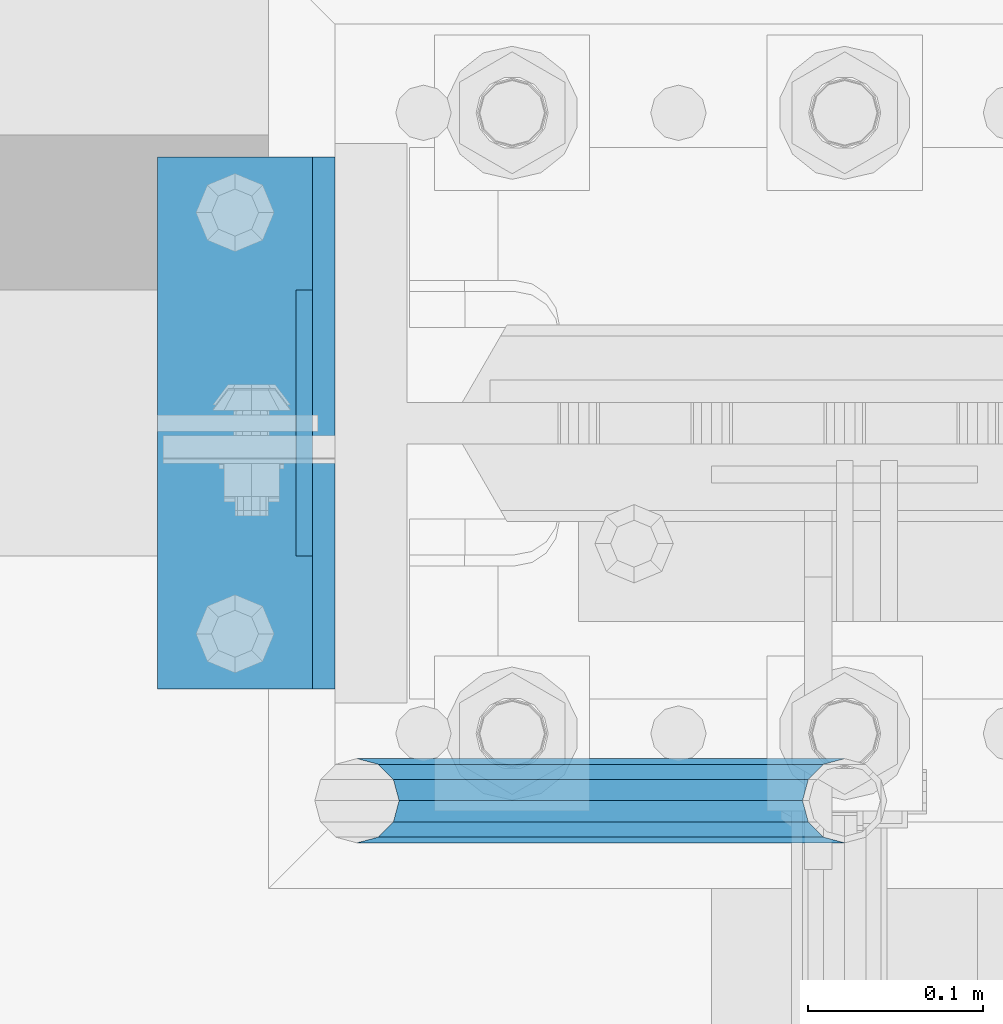
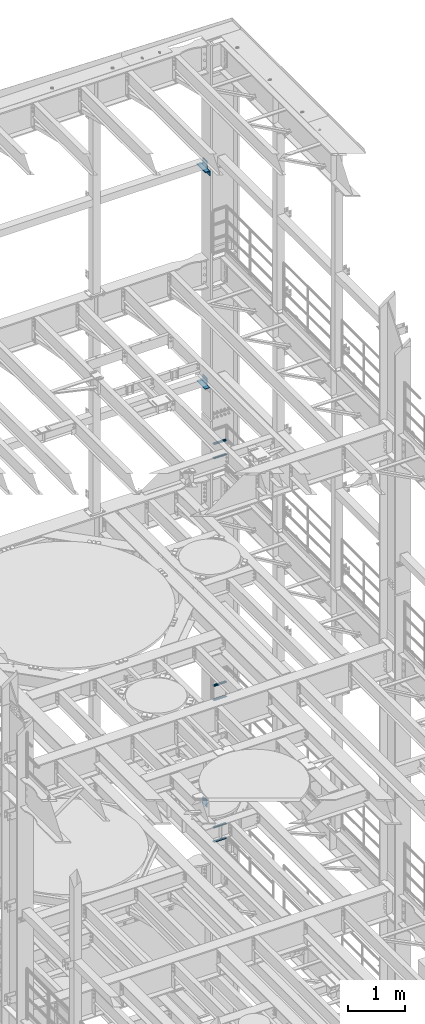
# One storey, part 1331 of 1876: 12 beams, 7 elements without a shape of their own.
"""IFC2X3 building model written with IfcOpenShell, lengths in millimetres."""

from ifc_helpers import new_model, si_unit, frame, origin_with_axes, place, context, subcontext, project, spatial, faceted_brep, material, type_object, element, aggregate, save


model = new_model("IFC2X3")

# Units and contexts
model_context = context("Model", 3, precision=1e-05, world=origin_with_axes())
body_context = subcontext(model_context, "Body", "Model", "MODEL_VIEW")
ifc_project = project(units=[si_unit("LENGTHUNIT", "METRE", prefix="MILLI"), si_unit("AREAUNIT", "SQUARE_METRE"), si_unit("VOLUMEUNIT", "CUBIC_METRE"), si_unit("MASSUNIT", "GRAM", prefix="KILO"), si_unit("TIMEUNIT", "SECOND"), si_unit("PLANEANGLEUNIT", "RADIAN"), si_unit("SOLIDANGLEUNIT", "STERADIAN"), si_unit("THERMODYNAMICTEMPERATUREUNIT", "DEGREE_CELSIUS"), si_unit("LUMINOUSINTENSITYUNIT", "LUMEN")], contexts=[model_context])

# Site, building, storey
site_placement = place(None, origin_with_axes())
site = spatial("IfcSite", under=ifc_project, at=site_placement, CompositionType="ELEMENT")
building_placement = place(site_placement, origin_with_axes())
building = spatial("IfcBuilding", under=site, at=building_placement, Name="Undefined", CompositionType="ELEMENT")
storey_placement = place(building_placement, origin_with_axes())
storey = spatial("IfcBuildingStorey", under=building, at=storey_placement, Name="Undefined", CompositionType="ELEMENT", Elevation=0.0)

# Assembly, beam
assembly_1_placement = place(storey_placement, origin_with_axes())
assembly_1 = element("IfcElementAssembly", 1, at=assembly_1_placement, inside=storey, Name="FRAME", AssemblyPlace="NOTDEFINED", PredefinedType="RIGID_FRAME")
ifc_material_1 = material(Name="STEEL/A36")
beam_type_1 = type_object("IfcBeamType", PredefinedType="NOTDEFINED")
beam_1_placement = place(assembly_1_placement, frame((7310.4375, 13639.8, 19958.05), z_axis=(0.0, 0.0, -1.0), x_axis=(0.0, 1.0, 0.0)))
beam_1 = element("IfcBeam", 2, at=beam_1_placement, type_object=beam_type_1, material=ifc_material_1, Name="PLATE", context=body_context, shape_type="Brep", body=[
    faceted_brep([(0.0, 4.76249999999982, -76.1999999999998), (3.63797880709171e-12, 4.76249999999982, 76.1999969482422), (152.399993896484, 4.76250000000073, 76.1999969482422), (152.4, 4.76249999999982, -76.1999999999998), (3.63797880709171e-12, -4.76249999999982, 76.1999969482422), (152.399993896484, -4.76250000000073, 76.1999969482422), (0.0, -4.76249999999982, -76.1999999999998), (152.4, -4.76249999999982, -76.1999999999998)], [[[0, 1, 2, 3]], [[4, 5, 2, 1]], [[4, 6, 7, 5]], [[6, 0, 3, 7]], [[5, 7, 3, 2]], [[6, 4, 1, 0]]]),
])

assembly_2_placement = place(storey_placement, origin_with_axes())
assembly_2 = element("IfcElementAssembly", 3, at=assembly_2_placement, inside=storey, Name="FRAME", AssemblyPlace="NOTDEFINED", PredefinedType="RIGID_FRAME")
beam_2_placement = place(assembly_2_placement, frame((7310.4375, 13639.8, 15335.25), z_axis=(0.0, 0.0, -1.0), x_axis=(0.0, 1.0, 0.0)))
beam_2 = element("IfcBeam", 4, at=beam_2_placement, type_object=beam_type_1, material=ifc_material_1, Name="PLATE", context=body_context, shape_type="Brep", body=[
    faceted_brep([(0.0, 4.76249999999982, -76.1999999999998), (3.63797880709171e-12, 4.76249999999982, 76.1999969482422), (152.399993896484, 4.76250000000073, 76.1999969482422), (152.4, 4.76249999999982, -76.1999999999998), (3.63797880709171e-12, -4.76249999999982, 76.1999969482422), (152.399993896484, -4.76250000000073, 76.1999969482422), (0.0, -4.76249999999982, -76.1999999999998), (152.4, -4.76249999999982, -76.1999999999998)], [[[0, 1, 2, 3]], [[4, 5, 2, 1]], [[4, 6, 7, 5]], [[6, 0, 3, 7]], [[5, 7, 3, 2]], [[6, 4, 1, 0]]]),
])

assembly_3_placement = place(storey_placement, origin_with_axes())
assembly_3 = element("IfcElementAssembly", 5, at=assembly_3_placement, inside=storey, Name="FRAME", AssemblyPlace="NOTDEFINED", PredefinedType="RIGID_FRAME")
beam_3_placement = place(assembly_3_placement, frame((7310.4375, 13639.8, 6330.95), z_axis=(0.0, 0.0, -1.0), x_axis=(0.0, 1.0, 0.0)))
beam_3 = element("IfcBeam", 6, at=beam_3_placement, type_object=beam_type_1, material=ifc_material_1, Name="PLATE", context=body_context, shape_type="Brep", body=[
    faceted_brep([(0.0, 4.76249999999982, -76.1999999999998), (3.63797880709171e-12, 4.76249999999982, 76.1999969482422), (152.399993896484, 4.76250000000073, 76.1999969482422), (152.4, 4.76249999999982, -76.1999999999998), (3.63797880709171e-12, -4.76249999999982, 76.1999969482422), (152.399993896484, -4.76250000000073, 76.1999969482422), (0.0, -4.76249999999982, -76.1999999999998), (152.4, -4.76249999999982, -76.1999999999998)], [[[0, 1, 2, 3]], [[4, 5, 2, 1]], [[4, 6, 7, 5]], [[6, 0, 3, 7]], [[5, 7, 3, 2]], [[6, 4, 1, 0]]]),
])
aggregate(assembly_3, [beam_3])

# Assembly, beams
assembly_4_placement = place(storey_placement, origin_with_axes())
assembly_4 = element("IfcElementAssembly", 7, at=assembly_4_placement, inside=storey, Name="RAIL", AssemblyPlace="NOTDEFINED", PredefinedType="RIGID_FRAME")
ifc_material_2 = material()
beam_type_2 = type_object("IfcBeamType", Name="PIPE1-1/2SCH40", PredefinedType="NOTDEFINED")
beam_4_placement = place(assembly_4_placement, frame((7619.99999999999, 13499.7063, 13776.325000036), z_axis=(0.0, 0.0, 1.0), x_axis=(-1.0, 0.0, 0.0)))
beam_4 = element("IfcBeam", 8, at=beam_4_placement, type_object=beam_type_2, material=ifc_material_2, Name="RAIL", ObjectType="PIPE1-1/2SCH40", context=body_context, shape_type="Brep", body=[
    faceted_brep([(258.502800903171, -12.0650000000005, 20.8971929933177), (258.502800903171, -12.0650000000005, 15.8661214311796), (258.009372465309, -10.2235000000001, 17.7076214311819), (255.26999389649, 0.0, 20.4470000000001), (255.26999389649, 0.0, 24.130000000001), (258.009372465309, 10.2235000000001, 17.7076214311819), (258.502800903171, 12.0650000000005, 15.8661214311796), (258.502800903171, 12.0650000000005, 20.8971929933177), (279.399993896489, 24.1299999999992, 0.0), (267.33499389649, 20.8971929933177, 12.0649999999987), (267.33499389649, 20.8971929933177, -12.0649999999987), (264.145422334351, 17.7076214311801, 10.2235000000001), (266.884800903171, 20.4470000000001, 0.0), (264.145422334351, 17.7076214311801, -10.2235000000001), (258.502800903171, 12.0650000000005, -15.8661214311796), (258.502800903171, 12.0650000000005, -20.8971929933177), (258.009372465309, 10.2235000000001, -17.7076214311819), (255.26999389649, 0.0, -20.4470000000001), (255.26999389649, 0.0, -24.130000000001), (258.502800903171, -12.0650000000005, -15.8661214311796), (258.502800903171, -12.0650000000005, -20.8971929933177), (258.009372465309, -10.2235000000001, -17.7076214311819), (279.399993896489, -24.1299999999992, 0.0), (267.33499389649, -20.8971929933177, -12.0649999999987), (267.33499389649, -20.8971929933177, 12.0649999999987), (264.145422334351, -17.7076214311801, -10.2235000000001), (266.884800903171, -20.4470000000001, 0.0), (264.145422334351, -17.7076214311801, 10.2235000000001), (12.0650000000064, -20.8971929933177, -12.0649999999987), (20.8971929933249, -12.0650000000005, -20.8971929933177), (0.0, 24.1299999999992, 0.0), (12.0650000000064, 20.8971929933177, -12.0649999999987), (12.0650000000064, 20.8971929933177, 12.0649999999987), (20.8971929933249, 12.0650000000005, 20.8971929933177), (24.1300000000064, 0.0, 24.130000000001), (20.8971929933249, 12.0650000000005, -20.8971929933177), (24.1300000000063, 0.0, -24.130000000001), (24.1300000000063, 0.0, -20.4470000000001), (20.8971929933249, -12.0650000000005, -15.8661214311796), (21.3906214311868, -10.2235000000001, -17.7076214311819), (21.3906214311868, 10.2235000000001, -17.7076214311819), (20.8971929933249, 12.0650000000005, -15.8661214311796), (15.2545715621445, 17.7076214311801, -10.2235000000001), (12.5151929933249, 20.4470000000001, 0.0), (15.2545715621445, 17.7076214311801, 10.2235000000001), (20.8971929933249, 12.0650000000005, 15.8661214311796), (21.3906214311868, 10.2235000000001, 17.7076214311819), (24.1300000000064, 0.0, 20.4470000000001), (21.3906214311868, -10.2235000000001, 17.7076214311819), (20.8971929933249, -12.0650000000005, 15.8661214311796), (20.8971929933249, -12.0650000000005, 20.8971929933177), (12.0650000000064, -20.8971929933177, 12.0649999999987), (0.0, -24.1299999999992, 0.0), (15.2545715621445, -17.7076214311801, 10.2235000000001), (12.5151929933249, -20.4470000000001, 0.0), (15.2545715621445, -17.7076214311801, -10.2235000000001)], [[[0, 1, 2, 3, 4]], [[4, 3, 5, 6, 7]], [[8, 9, 10]], [[7, 6, 11, 12, 13, 14, 15, 10, 9]], [[16, 17, 18, 15, 14]], [[19, 20, 18, 17, 21]], [[22, 23, 24]], [[24, 23, 20, 19, 25, 26, 27, 1, 0]], [[28, 29, 20, 23]], [[30, 31, 32]], [[33, 34, 4, 7]], [[32, 33, 7, 9]], [[30, 32, 9, 8]], [[31, 30, 8, 10]], [[35, 31, 10, 15]], [[36, 35, 15, 18]], [[29, 36, 18, 20]], [[37, 36, 29, 38, 39]], [[40, 41, 35, 36, 37]], [[32, 31, 35, 41, 42, 43, 44, 45, 33]], [[33, 45, 46, 47, 34]], [[34, 47, 48, 49, 50]], [[34, 50, 0, 4]], [[50, 51, 24, 0]], [[51, 52, 22, 24]], [[52, 28, 23, 22]], [[51, 28, 52]], [[50, 49, 53, 54, 55, 38, 29, 28, 51]], [[55, 54, 26, 25]], [[21, 39, 38, 55, 25, 19]], [[37, 39, 21, 17]], [[40, 37, 17, 16]], [[42, 41, 40, 16, 14, 13]], [[43, 42, 13, 12]], [[44, 43, 12, 11]], [[5, 46, 45, 44, 11, 6]], [[47, 46, 5, 3]], [[48, 47, 3, 2]], [[53, 49, 48, 2, 1, 27]], [[54, 53, 27, 26]]]),
])
beam_5_placement = place(assembly_4_placement, frame((7619.99999999999, 13499.7063, 14081.1250000359), z_axis=(0.0, 0.0, 1.0), x_axis=(-1.0, 0.0, 0.0)))
beam_5 = element("IfcBeam", 9, at=beam_5_placement, type_object=beam_type_2, material=ifc_material_2, Name="RAIL", ObjectType="PIPE1-1/2SCH40", context=body_context, shape_type="Brep", body=[
    faceted_brep([(258.502800903171, -12.0650000000005, 20.8971929933177), (258.502800903171, -12.0650000000005, 15.8661214311796), (258.009372465309, -10.2235000000001, 17.7076214311819), (255.26999389649, 0.0, 20.4470000000001), (255.26999389649, 0.0, 24.130000000001), (258.009372465309, 10.2235000000001, 17.7076214311819), (258.502800903171, 12.0650000000005, 15.8661214311796), (258.502800903171, 12.0650000000005, 20.8971929933177), (279.399993896489, 24.1299999999992, 0.0), (267.33499389649, 20.8971929933177, 12.0649999999987), (267.33499389649, 20.8971929933177, -12.0649999999987), (264.145422334351, 17.7076214311801, 10.2235000000001), (266.884800903171, 20.4470000000001, 0.0), (264.145422334351, 17.7076214311801, -10.2235000000001), (258.502800903171, 12.0650000000005, -15.8661214311796), (258.502800903171, 12.0650000000005, -20.8971929933177), (258.009372465309, 10.2235000000001, -17.7076214311819), (255.26999389649, 0.0, -20.4470000000001), (255.26999389649, 0.0, -24.130000000001), (258.502800903171, -12.0650000000005, -15.8661214311796), (258.502800903171, -12.0650000000005, -20.8971929933177), (258.009372465309, -10.2235000000001, -17.7076214311819), (279.399993896489, -24.1299999999992, 0.0), (267.33499389649, -20.8971929933177, -12.0649999999987), (267.33499389649, -20.8971929933177, 12.0649999999987), (264.145422334351, -17.7076214311801, -10.2235000000001), (266.884800903171, -20.4470000000001, 0.0), (264.145422334351, -17.7076214311801, 10.2235000000001), (12.0650000000064, -20.8971929933177, -12.0649999999987), (20.8971929933249, -12.0650000000005, -20.8971929933177), (0.0, 24.1299999999992, 0.0), (12.0650000000064, 20.8971929933177, -12.0649999999987), (12.0650000000064, 20.8971929933177, 12.0649999999987), (20.8971929933249, 12.0650000000005, 20.8971929933177), (24.1300000000064, 0.0, 24.130000000001), (20.8971929933249, 12.0650000000005, -20.8971929933177), (24.1300000000063, 0.0, -24.130000000001), (24.1300000000063, 0.0, -20.4470000000001), (20.8971929933249, -12.0650000000005, -15.8661214311796), (21.3906214311868, -10.2235000000001, -17.7076214311819), (21.3906214311868, 10.2235000000001, -17.7076214311819), (20.8971929933249, 12.0650000000005, -15.8661214311796), (15.2545715621445, 17.7076214311801, -10.2235000000001), (12.5151929933249, 20.4470000000001, 0.0), (15.2545715621445, 17.7076214311801, 10.2235000000001), (20.8971929933249, 12.0650000000005, 15.8661214311796), (21.3906214311868, 10.2235000000001, 17.7076214311819), (24.1300000000064, 0.0, 20.4470000000001), (21.3906214311868, -10.2235000000001, 17.7076214311819), (20.8971929933249, -12.0650000000005, 15.8661214311796), (20.8971929933249, -12.0650000000005, 20.8971929933177), (12.0650000000064, -20.8971929933177, 12.0649999999987), (0.0, -24.1299999999992, 0.0), (15.2545715621445, -17.7076214311801, 10.2235000000001), (12.5151929933249, -20.4470000000001, 0.0), (15.2545715621445, -17.7076214311801, -10.2235000000001)], [[[0, 1, 2, 3, 4]], [[4, 3, 5, 6, 7]], [[8, 9, 10]], [[7, 6, 11, 12, 13, 14, 15, 10, 9]], [[16, 17, 18, 15, 14]], [[19, 20, 18, 17, 21]], [[22, 23, 24]], [[24, 23, 20, 19, 25, 26, 27, 1, 0]], [[28, 29, 20, 23]], [[30, 31, 32]], [[33, 34, 4, 7]], [[32, 33, 7, 9]], [[30, 32, 9, 8]], [[31, 30, 8, 10]], [[35, 31, 10, 15]], [[36, 35, 15, 18]], [[29, 36, 18, 20]], [[37, 36, 29, 38, 39]], [[40, 41, 35, 36, 37]], [[32, 31, 35, 41, 42, 43, 44, 45, 33]], [[33, 45, 46, 47, 34]], [[34, 47, 48, 49, 50]], [[34, 50, 0, 4]], [[50, 51, 24, 0]], [[51, 52, 22, 24]], [[52, 28, 23, 22]], [[51, 28, 52]], [[50, 49, 53, 54, 55, 38, 29, 28, 51]], [[55, 54, 26, 25]], [[21, 39, 38, 55, 25, 19]], [[37, 39, 21, 17]], [[40, 37, 17, 16]], [[42, 41, 40, 16, 14, 13]], [[43, 42, 13, 12]], [[44, 43, 12, 11]], [[5, 46, 45, 44, 11, 6]], [[47, 46, 5, 3]], [[48, 47, 3, 2]], [[53, 49, 48, 2, 1, 27]], [[54, 53, 27, 26]]]),
])
aggregate(assembly_4, [beam_4, beam_5])

assembly_5_placement = place(storey_placement, origin_with_axes())
assembly_5 = element("IfcElementAssembly", 10, at=assembly_5_placement, inside=storey, Name="RAIL", AssemblyPlace="NOTDEFINED", PredefinedType="RIGID_FRAME")
beam_6_placement = place(assembly_5_placement, frame((7619.99999999999, 13499.7063, 8620.125000036), z_axis=(0.0, 0.0, 1.0), x_axis=(-1.0, 0.0, 0.0)))
beam_6 = element("IfcBeam", 11, at=beam_6_placement, type_object=beam_type_2, material=ifc_material_2, Name="RAIL", ObjectType="PIPE1-1/2SCH40", context=body_context, shape_type="Brep", body=[
    faceted_brep([(258.502800903171, -12.0650000000005, 20.8971929933177), (258.502800903171, -12.0650000000005, 15.8661214311796), (258.009372465309, -10.2235000000001, 17.7076214311819), (255.26999389649, 0.0, 20.4470000000001), (255.26999389649, 0.0, 24.130000000001), (258.009372465309, 10.2235000000001, 17.7076214311819), (258.502800903171, 12.0650000000005, 15.8661214311796), (258.502800903171, 12.0650000000005, 20.8971929933177), (279.399993896489, 24.1299999999992, 0.0), (267.33499389649, 20.8971929933177, 12.0649999999987), (267.33499389649, 20.8971929933177, -12.0649999999987), (264.145422334351, 17.7076214311801, 10.2235000000001), (266.884800903171, 20.4470000000001, 0.0), (264.145422334351, 17.7076214311801, -10.2235000000001), (258.502800903171, 12.0650000000005, -15.8661214311796), (258.502800903171, 12.0650000000005, -20.8971929933177), (258.009372465309, 10.2235000000001, -17.7076214311819), (255.26999389649, 0.0, -20.4470000000001), (255.26999389649, 0.0, -24.130000000001), (258.502800903171, -12.0650000000005, -15.8661214311796), (258.502800903171, -12.0650000000005, -20.8971929933177), (258.009372465309, -10.2235000000001, -17.7076214311819), (279.399993896489, -24.1299999999992, 0.0), (267.33499389649, -20.8971929933177, -12.0649999999987), (267.33499389649, -20.8971929933177, 12.0649999999987), (264.145422334351, -17.7076214311801, -10.2235000000001), (266.884800903171, -20.4470000000001, 0.0), (264.145422334351, -17.7076214311801, 10.2235000000001), (12.0650000000064, -20.8971929933177, -12.0649999999987), (20.8971929933249, -12.0650000000005, -20.8971929933177), (0.0, 24.1299999999992, 0.0), (12.0650000000064, 20.8971929933177, -12.0649999999987), (12.0650000000064, 20.8971929933177, 12.0649999999987), (20.8971929933249, 12.0650000000005, 20.8971929933177), (24.1300000000064, 0.0, 24.130000000001), (20.8971929933249, 12.0650000000005, -20.8971929933177), (24.1300000000063, 0.0, -24.130000000001), (24.1300000000063, 0.0, -20.4470000000001), (20.8971929933249, -12.0650000000005, -15.8661214311796), (21.3906214311868, -10.2235000000001, -17.7076214311819), (21.3906214311868, 10.2235000000001, -17.7076214311819), (20.8971929933249, 12.0650000000005, -15.8661214311796), (15.2545715621445, 17.7076214311801, -10.2235000000001), (12.5151929933249, 20.4470000000001, 0.0), (15.2545715621445, 17.7076214311801, 10.2235000000001), (20.8971929933249, 12.0650000000005, 15.8661214311796), (21.3906214311868, 10.2235000000001, 17.7076214311819), (24.1300000000064, 0.0, 20.4470000000001), (21.3906214311868, -10.2235000000001, 17.7076214311819), (20.8971929933249, -12.0650000000005, 15.8661214311796), (20.8971929933249, -12.0650000000005, 20.8971929933177), (12.0650000000064, -20.8971929933177, 12.0649999999987), (0.0, -24.1299999999992, 0.0), (15.2545715621445, -17.7076214311801, 10.2235000000001), (12.5151929933249, -20.4470000000001, 0.0), (15.2545715621445, -17.7076214311801, -10.2235000000001)], [[[0, 1, 2, 3, 4]], [[4, 3, 5, 6, 7]], [[8, 9, 10]], [[7, 6, 11, 12, 13, 14, 15, 10, 9]], [[16, 17, 18, 15, 14]], [[19, 20, 18, 17, 21]], [[22, 23, 24]], [[24, 23, 20, 19, 25, 26, 27, 1, 0]], [[28, 29, 20, 23]], [[30, 31, 32]], [[33, 34, 4, 7]], [[32, 33, 7, 9]], [[30, 32, 9, 8]], [[31, 30, 8, 10]], [[35, 31, 10, 15]], [[36, 35, 15, 18]], [[29, 36, 18, 20]], [[37, 36, 29, 38, 39]], [[40, 41, 35, 36, 37]], [[32, 31, 35, 41, 42, 43, 44, 45, 33]], [[33, 45, 46, 47, 34]], [[34, 47, 48, 49, 50]], [[34, 50, 0, 4]], [[50, 51, 24, 0]], [[51, 52, 22, 24]], [[52, 28, 23, 22]], [[51, 28, 52]], [[50, 49, 53, 54, 55, 38, 29, 28, 51]], [[55, 54, 26, 25]], [[21, 39, 38, 55, 25, 19]], [[37, 39, 21, 17]], [[40, 37, 17, 16]], [[42, 41, 40, 16, 14, 13]], [[43, 42, 13, 12]], [[44, 43, 12, 11]], [[5, 46, 45, 44, 11, 6]], [[47, 46, 5, 3]], [[48, 47, 3, 2]], [[53, 49, 48, 2, 1, 27]], [[54, 53, 27, 26]]]),
])
beam_7_placement = place(assembly_5_placement, frame((7619.99999999999, 13499.7063, 8924.92500003594), z_axis=(0.0, 0.0, 1.0), x_axis=(-1.0, 0.0, 0.0)))
beam_7 = element("IfcBeam", 12, at=beam_7_placement, type_object=beam_type_2, material=ifc_material_2, Name="RAIL", ObjectType="PIPE1-1/2SCH40", context=body_context, shape_type="Brep", body=[
    faceted_brep([(258.502800903171, -12.0650000000005, 20.8971929933177), (258.502800903171, -12.0650000000005, 15.8661214311796), (258.009372465309, -10.2235000000001, 17.7076214311819), (255.26999389649, 0.0, 20.4470000000001), (255.26999389649, 0.0, 24.130000000001), (258.009372465309, 10.2235000000001, 17.7076214311819), (258.502800903171, 12.0650000000005, 15.8661214311796), (258.502800903171, 12.0650000000005, 20.8971929933177), (279.399993896489, 24.1299999999992, 0.0), (267.33499389649, 20.8971929933177, 12.0649999999987), (267.33499389649, 20.8971929933177, -12.0649999999987), (264.145422334351, 17.7076214311801, 10.2235000000001), (266.884800903171, 20.4470000000001, 0.0), (264.145422334351, 17.7076214311801, -10.2235000000001), (258.502800903171, 12.0650000000005, -15.8661214311796), (258.502800903171, 12.0650000000005, -20.8971929933177), (258.009372465309, 10.2235000000001, -17.7076214311819), (255.26999389649, 0.0, -20.4470000000001), (255.26999389649, 0.0, -24.130000000001), (258.502800903171, -12.0650000000005, -15.8661214311796), (258.502800903171, -12.0650000000005, -20.8971929933177), (258.009372465309, -10.2235000000001, -17.7076214311819), (279.399993896489, -24.1299999999992, 0.0), (267.33499389649, -20.8971929933177, -12.0649999999987), (267.33499389649, -20.8971929933177, 12.0649999999987), (264.145422334351, -17.7076214311801, -10.2235000000001), (266.884800903171, -20.4470000000001, 0.0), (264.145422334351, -17.7076214311801, 10.2235000000001), (12.0650000000064, -20.8971929933177, -12.0649999999987), (20.8971929933249, -12.0650000000005, -20.8971929933177), (0.0, 24.1299999999992, 0.0), (12.0650000000064, 20.8971929933177, -12.0649999999987), (12.0650000000064, 20.8971929933177, 12.0649999999987), (20.8971929933249, 12.0650000000005, 20.8971929933177), (24.1300000000064, 0.0, 24.130000000001), (20.8971929933249, 12.0650000000005, -20.8971929933177), (24.1300000000063, 0.0, -24.130000000001), (24.1300000000063, 0.0, -20.4470000000001), (20.8971929933249, -12.0650000000005, -15.8661214311796), (21.3906214311868, -10.2235000000001, -17.7076214311819), (21.3906214311868, 10.2235000000001, -17.7076214311819), (20.8971929933249, 12.0650000000005, -15.8661214311796), (15.2545715621445, 17.7076214311801, -10.2235000000001), (12.5151929933249, 20.4470000000001, 0.0), (15.2545715621445, 17.7076214311801, 10.2235000000001), (20.8971929933249, 12.0650000000005, 15.8661214311796), (21.3906214311868, 10.2235000000001, 17.7076214311819), (24.1300000000064, 0.0, 20.4470000000001), (21.3906214311868, -10.2235000000001, 17.7076214311819), (20.8971929933249, -12.0650000000005, 15.8661214311796), (20.8971929933249, -12.0650000000005, 20.8971929933177), (12.0650000000064, -20.8971929933177, 12.0649999999987), (0.0, -24.1299999999992, 0.0), (15.2545715621445, -17.7076214311801, 10.2235000000001), (12.5151929933249, -20.4470000000001, 0.0), (15.2545715621445, -17.7076214311801, -10.2235000000001)], [[[0, 1, 2, 3, 4]], [[4, 3, 5, 6, 7]], [[8, 9, 10]], [[7, 6, 11, 12, 13, 14, 15, 10, 9]], [[16, 17, 18, 15, 14]], [[19, 20, 18, 17, 21]], [[22, 23, 24]], [[24, 23, 20, 19, 25, 26, 27, 1, 0]], [[28, 29, 20, 23]], [[30, 31, 32]], [[33, 34, 4, 7]], [[32, 33, 7, 9]], [[30, 32, 9, 8]], [[31, 30, 8, 10]], [[35, 31, 10, 15]], [[36, 35, 15, 18]], [[29, 36, 18, 20]], [[37, 36, 29, 38, 39]], [[40, 41, 35, 36, 37]], [[32, 31, 35, 41, 42, 43, 44, 45, 33]], [[33, 45, 46, 47, 34]], [[34, 47, 48, 49, 50]], [[34, 50, 0, 4]], [[50, 51, 24, 0]], [[51, 52, 22, 24]], [[52, 28, 23, 22]], [[51, 28, 52]], [[50, 49, 53, 54, 55, 38, 29, 28, 51]], [[55, 54, 26, 25]], [[21, 39, 38, 55, 25, 19]], [[37, 39, 21, 17]], [[40, 37, 17, 16]], [[42, 41, 40, 16, 14, 13]], [[43, 42, 13, 12]], [[44, 43, 12, 11]], [[5, 46, 45, 44, 11, 6]], [[47, 46, 5, 3]], [[48, 47, 3, 2]], [[53, 49, 48, 2, 1, 27]], [[54, 53, 27, 26]]]),
])
aggregate(assembly_5, [beam_6, beam_7])

assembly_6_placement = place(storey_placement, origin_with_axes())
assembly_6 = element("IfcElementAssembly", 13, at=assembly_6_placement, inside=storey, Name="RAIL", AssemblyPlace="NOTDEFINED", PredefinedType="RIGID_FRAME")
beam_8_placement = place(assembly_6_placement, frame((7619.99999999999, 13499.7063, 5597.525000036), z_axis=(0.0, 0.0, 1.0), x_axis=(-1.0, 0.0, 0.0)))
beam_8 = element("IfcBeam", 14, at=beam_8_placement, type_object=beam_type_2, material=ifc_material_2, Name="RAIL", ObjectType="PIPE1-1/2SCH40", context=body_context, shape_type="Brep", body=[
    faceted_brep([(258.502800903171, -12.0650000000005, 20.8971929933177), (258.502800903171, -12.0650000000005, 15.8661214311796), (258.009372465309, -10.2235000000001, 17.7076214311819), (255.26999389649, 0.0, 20.4470000000001), (255.26999389649, 0.0, 24.130000000001), (258.009372465309, 10.2235000000001, 17.7076214311819), (258.502800903171, 12.0650000000005, 15.8661214311796), (258.502800903171, 12.0650000000005, 20.8971929933177), (279.399993896489, 24.1299999999992, 0.0), (267.33499389649, 20.8971929933177, 12.0649999999987), (267.33499389649, 20.8971929933177, -12.0649999999987), (264.145422334351, 17.7076214311801, 10.2235000000001), (266.884800903171, 20.4470000000001, 0.0), (264.145422334351, 17.7076214311801, -10.2235000000001), (258.502800903171, 12.0650000000005, -15.8661214311796), (258.502800903171, 12.0650000000005, -20.8971929933177), (258.009372465309, 10.2235000000001, -17.7076214311819), (255.26999389649, 0.0, -20.4470000000001), (255.26999389649, 0.0, -24.130000000001), (258.502800903171, -12.0650000000005, -15.8661214311796), (258.502800903171, -12.0650000000005, -20.8971929933177), (258.009372465309, -10.2235000000001, -17.7076214311819), (279.399993896489, -24.1299999999992, 0.0), (267.33499389649, -20.8971929933177, -12.0649999999987), (267.33499389649, -20.8971929933177, 12.0649999999987), (264.145422334351, -17.7076214311801, -10.2235000000001), (266.884800903171, -20.4470000000001, 0.0), (264.145422334351, -17.7076214311801, 10.2235000000001), (12.0650000000064, -20.8971929933177, -12.0649999999987), (20.8971929933249, -12.0650000000005, -20.8971929933177), (0.0, 24.1299999999992, 0.0), (12.0650000000064, 20.8971929933177, -12.0649999999987), (12.0650000000064, 20.8971929933177, 12.0649999999987), (20.8971929933249, 12.0650000000005, 20.8971929933177), (24.1300000000064, 0.0, 24.130000000001), (20.8971929933249, 12.0650000000005, -20.8971929933177), (24.1300000000063, 0.0, -24.130000000001), (24.1300000000063, 0.0, -20.4470000000001), (20.8971929933249, -12.0650000000005, -15.8661214311796), (21.3906214311868, -10.2235000000001, -17.7076214311819), (21.3906214311868, 10.2235000000001, -17.7076214311819), (20.8971929933249, 12.0650000000005, -15.8661214311796), (15.2545715621445, 17.7076214311801, -10.2235000000001), (12.5151929933249, 20.4470000000001, 0.0), (15.2545715621445, 17.7076214311801, 10.2235000000001), (20.8971929933249, 12.0650000000005, 15.8661214311796), (21.3906214311868, 10.2235000000001, 17.7076214311819), (24.1300000000064, 0.0, 20.4470000000001), (21.3906214311868, -10.2235000000001, 17.7076214311819), (20.8971929933249, -12.0650000000005, 15.8661214311796), (20.8971929933249, -12.0650000000005, 20.8971929933177), (12.0650000000064, -20.8971929933177, 12.0649999999987), (0.0, -24.1299999999992, 0.0), (15.2545715621445, -17.7076214311801, 10.2235000000001), (12.5151929933249, -20.4470000000001, 0.0), (15.2545715621445, -17.7076214311801, -10.2235000000001)], [[[0, 1, 2, 3, 4]], [[4, 3, 5, 6, 7]], [[8, 9, 10]], [[7, 6, 11, 12, 13, 14, 15, 10, 9]], [[16, 17, 18, 15, 14]], [[19, 20, 18, 17, 21]], [[22, 23, 24]], [[24, 23, 20, 19, 25, 26, 27, 1, 0]], [[28, 29, 20, 23]], [[30, 31, 32]], [[33, 34, 4, 7]], [[32, 33, 7, 9]], [[30, 32, 9, 8]], [[31, 30, 8, 10]], [[35, 31, 10, 15]], [[36, 35, 15, 18]], [[29, 36, 18, 20]], [[37, 36, 29, 38, 39]], [[40, 41, 35, 36, 37]], [[32, 31, 35, 41, 42, 43, 44, 45, 33]], [[33, 45, 46, 47, 34]], [[34, 47, 48, 49, 50]], [[34, 50, 0, 4]], [[50, 51, 24, 0]], [[51, 52, 22, 24]], [[52, 28, 23, 22]], [[51, 28, 52]], [[50, 49, 53, 54, 55, 38, 29, 28, 51]], [[55, 54, 26, 25]], [[21, 39, 38, 55, 25, 19]], [[37, 39, 21, 17]], [[40, 37, 17, 16]], [[42, 41, 40, 16, 14, 13]], [[43, 42, 13, 12]], [[44, 43, 12, 11]], [[5, 46, 45, 44, 11, 6]], [[47, 46, 5, 3]], [[48, 47, 3, 2]], [[53, 49, 48, 2, 1, 27]], [[54, 53, 27, 26]]]),
])
beam_9_placement = place(assembly_6_placement, frame((7619.99999999999, 13499.7063, 5902.32500003594), z_axis=(0.0, 0.0, 1.0), x_axis=(-1.0, 0.0, 0.0)))
beam_9 = element("IfcBeam", 15, at=beam_9_placement, type_object=beam_type_2, material=ifc_material_2, Name="RAIL", ObjectType="PIPE1-1/2SCH40", context=body_context, shape_type="Brep", body=[
    faceted_brep([(258.502800903171, -12.0650000000005, 20.8971929933177), (258.502800903171, -12.0650000000005, 15.8661214311796), (258.009372465309, -10.2235000000001, 17.7076214311819), (255.26999389649, 0.0, 20.4470000000001), (255.26999389649, 0.0, 24.130000000001), (258.009372465309, 10.2235000000001, 17.7076214311819), (258.502800903171, 12.0650000000005, 15.8661214311796), (258.502800903171, 12.0650000000005, 20.8971929933177), (279.399993896489, 24.1299999999992, 0.0), (267.33499389649, 20.8971929933177, 12.0649999999987), (267.33499389649, 20.8971929933177, -12.0649999999987), (264.145422334351, 17.7076214311801, 10.2235000000001), (266.884800903171, 20.4470000000001, 0.0), (264.145422334351, 17.7076214311801, -10.2235000000001), (258.502800903171, 12.0650000000005, -15.8661214311796), (258.502800903171, 12.0650000000005, -20.8971929933177), (258.009372465309, 10.2235000000001, -17.7076214311819), (255.26999389649, 0.0, -20.4470000000001), (255.26999389649, 0.0, -24.130000000001), (258.502800903171, -12.0650000000005, -15.8661214311796), (258.502800903171, -12.0650000000005, -20.8971929933177), (258.009372465309, -10.2235000000001, -17.7076214311819), (279.399993896489, -24.1299999999992, 0.0), (267.33499389649, -20.8971929933177, -12.0649999999987), (267.33499389649, -20.8971929933177, 12.0649999999987), (264.145422334351, -17.7076214311801, -10.2235000000001), (266.884800903171, -20.4470000000001, 0.0), (264.145422334351, -17.7076214311801, 10.2235000000001), (12.0650000000064, -20.8971929933177, -12.0649999999987), (20.8971929933249, -12.0650000000005, -20.8971929933177), (0.0, 24.1299999999992, 0.0), (12.0650000000064, 20.8971929933177, -12.0649999999987), (12.0650000000064, 20.8971929933177, 12.0649999999987), (20.8971929933249, 12.0650000000005, 20.8971929933177), (24.1300000000064, 0.0, 24.130000000001), (20.8971929933249, 12.0650000000005, -20.8971929933177), (24.1300000000063, 0.0, -24.130000000001), (24.1300000000063, 0.0, -20.4470000000001), (20.8971929933249, -12.0650000000005, -15.8661214311796), (21.3906214311868, -10.2235000000001, -17.7076214311819), (21.3906214311868, 10.2235000000001, -17.7076214311819), (20.8971929933249, 12.0650000000005, -15.8661214311796), (15.2545715621445, 17.7076214311801, -10.2235000000001), (12.5151929933249, 20.4470000000001, 0.0), (15.2545715621445, 17.7076214311801, 10.2235000000001), (20.8971929933249, 12.0650000000005, 15.8661214311796), (21.3906214311868, 10.2235000000001, 17.7076214311819), (24.1300000000064, 0.0, 20.4470000000001), (21.3906214311868, -10.2235000000001, 17.7076214311819), (20.8971929933249, -12.0650000000005, 15.8661214311796), (20.8971929933249, -12.0650000000005, 20.8971929933177), (12.0650000000064, -20.8971929933177, 12.0649999999987), (0.0, -24.1299999999992, 0.0), (15.2545715621445, -17.7076214311801, 10.2235000000001), (12.5151929933249, -20.4470000000001, 0.0), (15.2545715621445, -17.7076214311801, -10.2235000000001)], [[[0, 1, 2, 3, 4]], [[4, 3, 5, 6, 7]], [[8, 9, 10]], [[7, 6, 11, 12, 13, 14, 15, 10, 9]], [[16, 17, 18, 15, 14]], [[19, 20, 18, 17, 21]], [[22, 23, 24]], [[24, 23, 20, 19, 25, 26, 27, 1, 0]], [[28, 29, 20, 23]], [[30, 31, 32]], [[33, 34, 4, 7]], [[32, 33, 7, 9]], [[30, 32, 9, 8]], [[31, 30, 8, 10]], [[35, 31, 10, 15]], [[36, 35, 15, 18]], [[29, 36, 18, 20]], [[37, 36, 29, 38, 39]], [[40, 41, 35, 36, 37]], [[32, 31, 35, 41, 42, 43, 44, 45, 33]], [[33, 45, 46, 47, 34]], [[34, 47, 48, 49, 50]], [[34, 50, 0, 4]], [[50, 51, 24, 0]], [[51, 52, 22, 24]], [[52, 28, 23, 22]], [[51, 28, 52]], [[50, 49, 53, 54, 55, 38, 29, 28, 51]], [[55, 54, 26, 25]], [[21, 39, 38, 55, 25, 19]], [[37, 39, 21, 17]], [[40, 37, 17, 16]], [[42, 41, 40, 16, 14, 13]], [[43, 42, 13, 12]], [[44, 43, 12, 11]], [[5, 46, 45, 44, 11, 6]], [[47, 46, 5, 3]], [[48, 47, 3, 2]], [[53, 49, 48, 2, 1, 27]], [[54, 53, 27, 26]]]),
])
aggregate(assembly_6, [beam_8, beam_9])

# Beam
beam_type_3 = type_object("IfcBeamType", PredefinedType="NOTDEFINED")
beam_10_placement = place(assembly_1_placement, frame((7270.75, 13563.6, 19877.0875), z_axis=(-1.0, 0.0, 0.0), x_axis=(0.0, 1.0, 0.0)))
beam_10 = element("IfcBeam", 16, at=beam_10_placement, type_object=beam_type_3, material=ifc_material_1, Name="PLATE", context=body_context, shape_type="Brep", body=[
    faceted_brep([(0.0, 4.76250000000073, -44.4499999999998), (0.0, 4.76250000000073, 44.4499999999998), (304.799999999999, 4.76250000000073, 44.4499999999998), (304.799999999999, 4.76250000000073, -44.4499999999998), (0.0, -4.76250000000073, 44.4499999999998), (304.799999999999, -4.76250000000073, 44.4499999999998), (0.0, -4.76250000000073, -44.4499999999998), (304.799999999999, -4.76250000000073, -44.4499999999998)], [[[0, 1, 2, 3]], [[1, 4, 5, 2]], [[4, 6, 7, 5]], [[6, 0, 3, 7]], [[5, 7, 3, 2]], [[6, 4, 1, 0]]]),
])

aggregate(assembly_1, [beam_1, beam_10])

beam_11_placement = place(assembly_2_placement, frame((7270.75, 13563.6, 15254.2875), z_axis=(-1.0, 0.0, 0.0), x_axis=(0.0, 1.0, 0.0)))
beam_11 = element("IfcBeam", 17, at=beam_11_placement, type_object=beam_type_3, material=ifc_material_1, Name="PLATE", context=body_context, shape_type="Brep", body=[
    faceted_brep([(0.0, 4.76250000000073, -44.4499999999998), (0.0, 4.76250000000073, 44.4499999999998), (304.799999999999, 4.76250000000073, 44.4499999999998), (304.799999999999, 4.76250000000073, -44.4499999999998), (0.0, -4.76250000000073, 44.4499999999998), (304.799999999999, -4.76250000000073, 44.4499999999998), (0.0, -4.76250000000073, -44.4499999999998), (304.799999999999, -4.76250000000073, -44.4499999999998)], [[[0, 1, 2, 3]], [[1, 4, 5, 2]], [[4, 6, 7, 5]], [[6, 0, 3, 7]], [[5, 7, 3, 2]], [[6, 4, 1, 0]]]),
])

aggregate(assembly_2, [beam_2, beam_11])

# Assembly, beam
assembly_7_placement = place(storey_placement, origin_with_axes())
assembly_7 = element("IfcElementAssembly", 18, at=assembly_7_placement, inside=storey, Name="COLUMN", AssemblyPlace="NOTDEFINED", PredefinedType="RIGID_FRAME")
beam_type_4 = type_object("IfcBeamType", Name="L4X4X3/8", PredefinedType="NOTDEFINED")
beam_12_placement = place(assembly_7_placement, frame((7277.1, 13868.4, 19821.525), z_axis=(-1.0, 0.0, 0.0), x_axis=(0.0, -1.0, 0.0)))
beam_12 = element("IfcBeam", 19, at=beam_12_placement, type_object=beam_type_4, material=ifc_material_1, Name="ANGLE", ObjectType="L4X4X3/8", context=body_context, shape_type="Brep", body=[
    faceted_brep([(0.0, 50.7999999999993, -50.8000000000002), (0.0, 50.7999999999993, 50.8000000000002), (304.799999999999, 50.7999999999993, 50.8000000000002), (304.799999999999, 50.7999999999993, -50.8000000000002), (0.0, 41.2750000000015, 50.8000000000002), (304.799999999999, 41.2750000000015, 50.8000000000002), (0.0, 41.2750000000015, -41.2749999999996), (304.799999999999, 41.2750000000015, -41.2749999999996), (0.0, -50.7999999999993, -41.2749999999996), (304.799999999999, -50.7999999999993, -41.2749999999996), (0.0, -50.7999999999993, -50.8000000000002), (304.799999999999, -50.7999999999993, -50.8000000000002)], [[[0, 1, 2, 3]], [[1, 4, 5, 2]], [[4, 6, 7, 5]], [[6, 8, 9, 7]], [[8, 10, 11, 9]], [[10, 0, 3, 11]], [[5, 7, 9, 11, 3, 2]], [[10, 8, 6, 4, 1, 0]]]),
])
aggregate(assembly_7, [beam_12])

save(model, "model.ifc")
